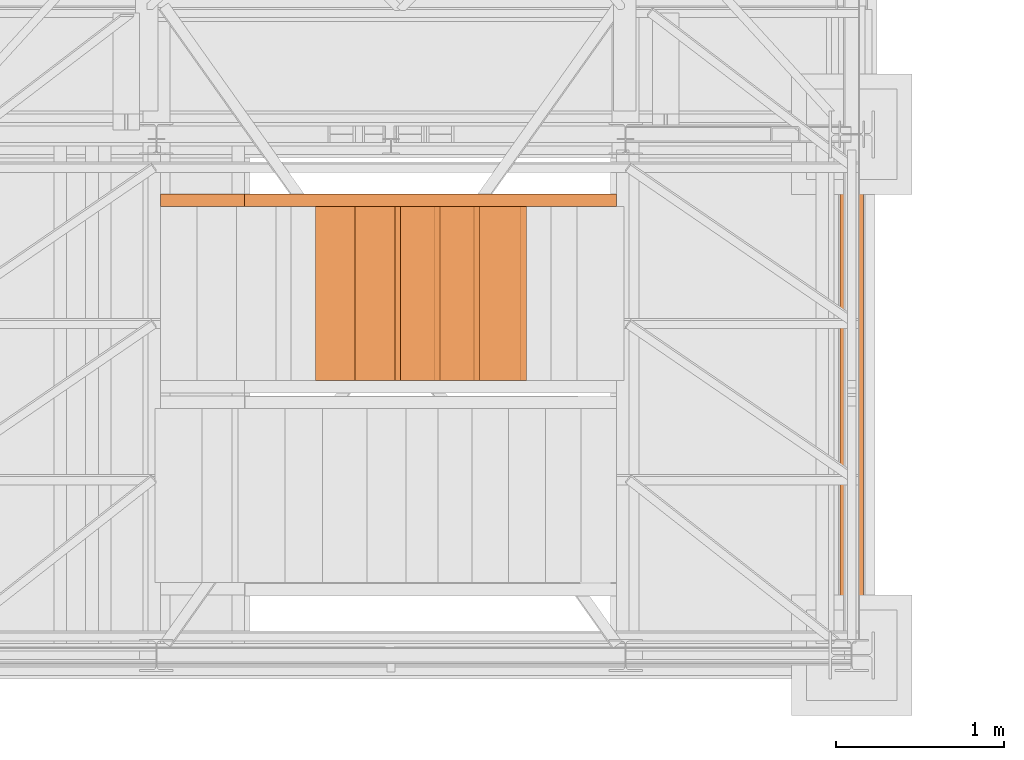
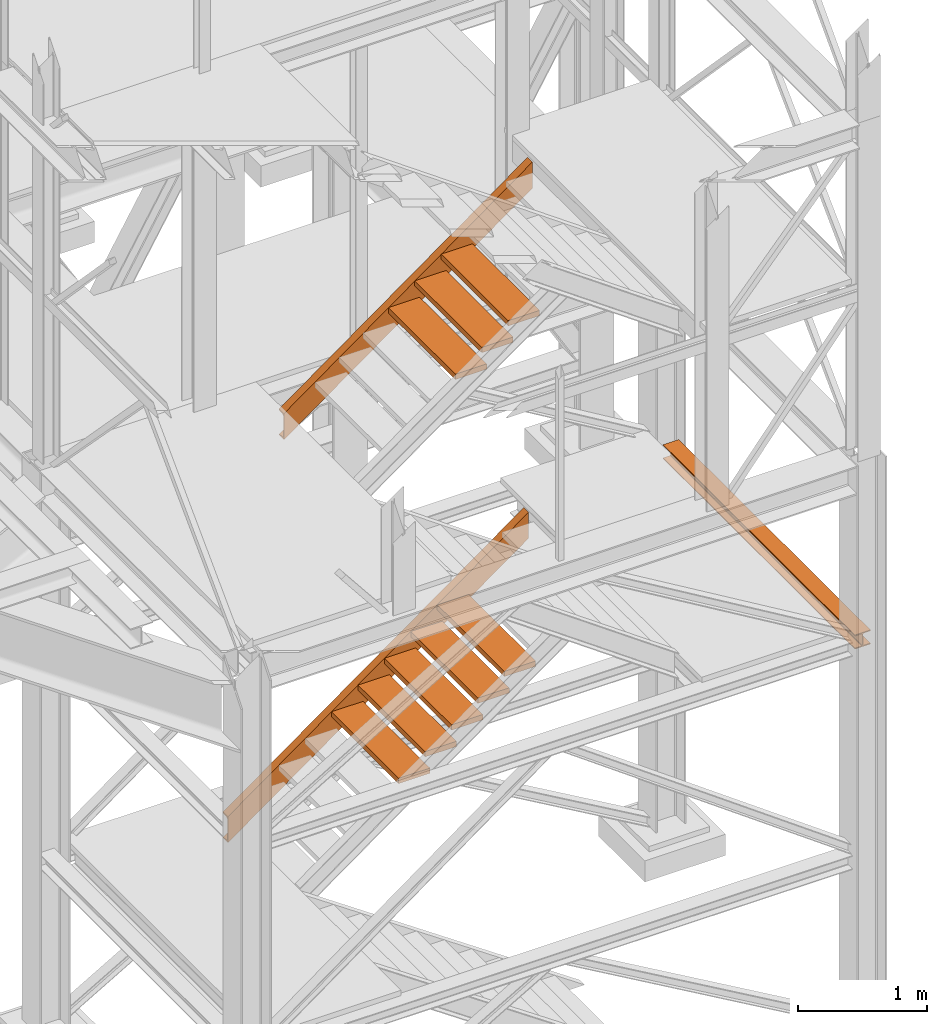
# One storey, part 52 of 208: 11 proxies.
"""IFC2X3 building model written with IfcOpenShell, lengths in millimetres."""

from ifc_helpers import new_model, entity, si_unit, converted_unit, frame, origin, origin_with_axes, place, context, subcontext, project, spatial, faceted_brep, element, save


model = new_model("IFC2X3")

# Units and contexts
model_context = context("Model", 3, precision=1e-05, world=origin())
plan_context = context("Plan", 3, precision=1e-05, world=origin())
body_context = subcontext(model_context, "Body", "Model", "MODEL_VIEW")
ifc_project = project(units=[si_unit("LENGTHUNIT", "METRE", prefix="MILLI"), converted_unit("PLANEANGLEUNIT", "DEGREE", entity("IfcPlaneAngleMeasure", 0.0174532925199433), si_unit("PLANEANGLEUNIT", "RADIAN"), dimensions=[0, 0, 0, 0, 0, 0, 0]), si_unit("AREAUNIT", "SQUARE_METRE"), si_unit("VOLUMEUNIT", "CUBIC_METRE")], contexts=[model_context, plan_context])

# Building, storey
building_placement = place(None, origin())
building = spatial("IfcBuilding", under=ifc_project, at=building_placement, CompositionType="COMPLEX")
storey_placement = place(building_placement, origin_with_axes())
storey = spatial("IfcBuildingStorey", under=building, at=storey_placement, Name="Geschoss", CompositionType="ELEMENT")

# Proxies
proxy_1_placement = place(storey_placement, frame((2573.108528797216, -22492.72083116692, 1416.268085031043), z_axis=(0.0, 0.0, 1.0), x_axis=(1.0, 0.0, 0.0)))
element("IfcBuildingElementProxy", 1, at=proxy_1_placement, inside=storey, context=body_context, shape_type="Brep", body=[
    faceted_brep([(0.01000000000112777, 0.00999999999839929, 0.01000000000021828), (0.01000000000112777, 0.00999999999839929, 246.5232555097177), (2685.302879462902, 0.00999999999839929, 2181.461873163844), (2685.302879462901, 0.00999999999839929, 1934.948617654126), (0.01000000000112777, 75.01000111758549, 0.01000000000021828), (0.01000000000112777, 0.00999999999839929, 0.01000000000021828), (2685.302879462901, 0.00999999999839929, 1934.948617654126), (2685.302879462901, 75.01000111758549, 1934.948617654126), (0.01000000000112777, 75.01000111758549, 3.659420299631847), (0.01000000000112777, 75.01000111758549, 0.01000000000021828), (2685.302879462901, 75.01000111758549, 1934.948617654126), (2685.302879462902, 75.01000111758549, 1938.598037953758), (0.01000000000203727, 73.89400100171406, 9.080250677066488), (0.01000000000112777, 75.01000111758549, 3.659420299631847), (2685.302879462902, 75.01000111758549, 1938.598037953758), (2685.302879462902, 73.89400100171406, 1944.018868331193), (0.01000000000112777, 69.488472694753, 11.03126840622554), (0.01000000000203727, 73.89400100171406, 9.080250677066488), (2685.302879462902, 73.89400100171406, 1944.018868331193), (2685.302879462902, 69.488472694753, 1945.969886060354), (0.01000000000112777, 19.09293180167515, 16.0005358716694), (0.01000000000112777, 69.488472694753, 11.03126840622554), (2685.302879462902, 69.488472694753, 1945.969886060354), (2685.302879462902, 19.09293180167515, 1950.939153525796), (0.01000000000112777, 13.35380079060633, 17.96675201902212), (0.01000000000112777, 19.09293180167515, 16.0005358716694), (2685.302879462902, 19.09293180167515, 1950.939153525796), (2685.302879462902, 13.35380079060633, 1952.905369673149), (0.01000000000203727, 9.500150026975462, 23.24250408189437), (0.01000000000112777, 13.35380079060633, 17.96675201902212), (2685.302879462902, 13.35380079060633, 1952.905369673149), (2685.302879462902, 9.500150026975462, 1958.181121736021), (0.01000000000021828, 8.510000461934396, 30.12990375652862), (0.01000000000203727, 9.500150026975462, 23.24250408189437), (2685.302879462902, 9.500150026975462, 1958.181121736021), (2685.302879462901, 8.510000461934396, 1965.068521410656), (0.01000000000112777, 8.510000461934396, 216.4033517531852), (0.01000000000021828, 8.510000461934396, 30.12990375652862), (2685.302879462901, 8.510000461934396, 1965.068521410656), (2685.302879462902, 8.510000461934396, 2151.341969407312), (0.01000000000112777, 9.500150026975462, 223.2907514278231), (0.01000000000112777, 8.510000461934396, 216.4033517531852), (2685.302879462902, 8.510000461934396, 2151.341969407312), (2685.302879462901, 9.500150026975462, 2158.229369081949), (0.01000000000112777, 13.35380079060633, 228.566503490694), (0.01000000000112777, 9.500150026975462, 223.2907514278231), (2685.302879462901, 9.500150026975462, 2158.229369081949), (2685.302879462901, 13.35380079060633, 2163.505121144821), (0.01000000000112777, 19.09293180167515, 230.5327196380472), (0.01000000000112777, 13.35380079060633, 228.566503490694), (2685.302879462901, 13.35380079060633, 2163.505121144821), (2685.302879462902, 19.09293180167515, 2165.471337292173), (0.01000000000112777, 69.488472694753, 235.5019871034892), (0.01000000000112777, 19.09293180167515, 230.5327196380472), (2685.302879462902, 19.09293180167515, 2165.471337292173), (2685.302879462902, 69.488472694753, 2170.440604757616), (0.01000000000112777, 73.89400100171406, 237.4530048326515), (0.01000000000112777, 69.488472694753, 235.5019871034892), (2685.302879462902, 69.488472694753, 2170.440604757616), (2685.302879462902, 73.89400100171406, 2172.391622486778), (0.01000000000112777, 75.01000111758549, 242.873835210085), (0.01000000000112777, 73.89400100171406, 237.4530048326515), (2685.302879462902, 73.89400100171406, 2172.391622486778), (2685.302879462902, 75.01000111758549, 2177.812452864211), (0.01000000000112777, 75.01000111758549, 246.5232555097175), (0.01000000000112777, 75.01000111758549, 242.873835210085), (2685.302879462902, 75.01000111758549, 2177.812452864211), (2685.302879462902, 75.01000111758549, 2181.461873163844), (0.01000000000112777, 0.00999999999839929, 246.5232555097177), (0.01000000000112777, 75.01000111758549, 246.5232555097175), (2685.302879462902, 75.01000111758549, 2181.461873163844), (2685.302879462902, 0.00999999999839929, 2181.461873163844), (2685.302879462901, 0.00999999999839929, 1934.948617654126), (2685.302879462902, 0.00999999999839929, 2181.461873163844), (2685.302879462902, 75.01000111758549, 2181.461873163844), (2685.302879462902, 75.01000111758549, 2177.812452864211), (2685.302879462902, 73.89400100171406, 2172.391622486778), (2685.302879462902, 69.488472694753, 2170.440604757616), (2685.302879462902, 19.09293180167515, 2165.471337292173), (2685.302879462901, 13.35380079060633, 2163.505121144821), (2685.302879462901, 9.500150026975462, 2158.229369081949), (2685.302879462902, 8.510000461934396, 2151.341969407312), (2685.302879462901, 8.510000461934396, 1965.068521410656), (2685.302879462902, 9.500150026975462, 1958.181121736021), (2685.302879462902, 13.35380079060633, 1952.905369673149), (2685.302879462902, 19.09293180167515, 1950.939153525796), (2685.302879462902, 69.488472694753, 1945.969886060354), (2685.302879462902, 73.89400100171406, 1944.018868331193), (2685.302879462902, 75.01000111758549, 1938.598037953758), (2685.302879462901, 75.01000111758549, 1934.948617654126), (0.01000000000112777, 0.00999999999839929, 246.5232555097177), (0.01000000000112777, 0.00999999999839929, 0.01000000000021828), (0.01000000000112777, 75.01000111758549, 0.01000000000021828), (0.01000000000112777, 75.01000111758549, 3.659420299631847), (0.01000000000203727, 73.89400100171406, 9.080250677066488), (0.01000000000112777, 69.488472694753, 11.03126840622554), (0.01000000000112777, 19.09293180167515, 16.0005358716694), (0.01000000000112777, 13.35380079060633, 17.96675201902212), (0.01000000000203727, 9.500150026975462, 23.24250408189437), (0.01000000000021828, 8.510000461934396, 30.12990375652862), (0.01000000000112777, 8.510000461934396, 216.4033517531852), (0.01000000000112777, 9.500150026975462, 223.2907514278231), (0.01000000000112777, 13.35380079060633, 228.566503490694), (0.01000000000112777, 19.09293180167515, 230.5327196380472), (0.01000000000112777, 69.488472694753, 235.5019871034892), (0.01000000000112777, 73.89400100171406, 237.4530048326515), (0.01000000000112777, 75.01000111758549, 242.873835210085), (0.01000000000112777, 75.01000111758549, 246.5232555097175)], [[[0, 1, 2, 3]], [[4, 5, 6, 7]], [[8, 9, 10, 11]], [[12, 13, 14, 15]], [[16, 17, 18, 19]], [[20, 21, 22, 23]], [[24, 25, 26, 27]], [[28, 29, 30, 31]], [[32, 33, 34, 35]], [[36, 37, 38, 39]], [[40, 41, 42, 43]], [[44, 45, 46, 47]], [[48, 49, 50, 51]], [[52, 53, 54, 55]], [[56, 57, 58, 59]], [[60, 61, 62, 63]], [[64, 65, 66, 67]], [[68, 69, 70, 71]], [[72, 73, 74, 75, 76, 77, 78, 79, 80, 81, 82, 83, 84, 85, 86, 87, 88, 89]], [[90, 91, 92, 93, 94, 95, 96, 97, 98, 99, 100, 101, 102, 103, 104, 105, 106, 107]]], orient=[[False], [False], [False], [False], [False], [False], [False], [False], [False], [False], [False], [False], [False], [False], [False], [False], [False], [False], [False], [False]]),
])
for number, where, z_axis, x_axis in (
    (2, (3499.055558253344, -23530.42800187884, 2279.990001055714), (0.0, 0.0, 1.0), (1.0, 0.0, 0.0)),
    (3, (3734.980246170392, -23530.42800187884, 2449.990001055715), (0.0, 0.0, 1.0), (1.0, 0.0, 0.0)),
):
    element("IfcBuildingElementProxy", number, at=place(storey_placement, frame(where, z_axis=z_axis, x_axis=x_axis)), inside=storey, context=body_context, shape_type="Brep", body=[
        faceted_brep([(0.01000000000021828, 0.00999999999839929, 0.01000000000021828), (280.2746556316183, 0.00999999999839929, 0.01000000000021828), (280.2746556316183, 1037.717170711916, 0.01000000000021828), (0.01000000000021828, 1037.717170711916, 0.01000000000021828), (280.2746556316183, 0.00999999999839929, 50.01000000000022), (0.01000000000021828, 0.00999999999839929, 50.01000000000022), (0.01000000000021828, 1037.717170711916, 50.01000000000022), (280.2746556316183, 1037.717170711916, 50.01000000000022), (280.2746556316183, 0.00999999999839929, 0.01000000000021828), (0.01000000000021828, 0.00999999999839929, 0.01000000000021828), (0.01000000000021828, 0.00999999999839929, 50.01000000000022), (280.2746556316183, 0.00999999999839929, 50.01000000000022), (280.2746556316183, 1037.717170711916, 0.01000000000021828), (280.2746556316183, 0.00999999999839929, 0.01000000000021828), (280.2746556316183, 0.00999999999839929, 50.01000000000022), (280.2746556316183, 1037.717170711916, 50.01000000000022), (0.01000000000021828, 1037.717170711916, 0.01000000000021828), (280.2746556316183, 1037.717170711916, 0.01000000000021828), (280.2746556316183, 1037.717170711916, 50.01000000000022), (0.01000000000021828, 1037.717170711916, 50.01000000000022), (0.01000000000021828, 0.00999999999839929, 0.01000000000021828), (0.01000000000021828, 1037.717170711916, 0.01000000000021828), (0.01000000000021828, 1037.717170711916, 50.01000000000022), (0.01000000000021828, 0.00999999999839929, 50.01000000000022)], [[[0, 1, 2, 3]], [[4, 5, 6, 7]], [[8, 9, 10, 11]], [[12, 13, 14, 15]], [[16, 17, 18, 19]], [[20, 21, 22, 23]]], orient=[[False], [False], [False], [False], [False], [False]]),
    ])
for number, where, z_axis, x_axis in (
    (4, (3970.904934087441, -23530.42800187884, 2619.990001055715), (0.0, 0.0, 1.0), (1.0, 0.0, 0.0)),
    (5, (4206.829622004489, -23530.42800187884, 2789.990001055716), (0.0, 0.0, 1.0), (1.0, 0.0, 0.0)),
    (6, (4442.754309921536, -23530.42800187884, 2959.990001055716), (0.0, 0.0, 1.0), (1.0, 0.0, 0.0)),
):
    element("IfcBuildingElementProxy", number, at=place(storey_placement, frame(where, z_axis=z_axis, x_axis=x_axis)), inside=storey, context=body_context, shape_type="Brep", body=[
        faceted_brep([(0.009999999999308784, 0.00999999999839929, 0.01000000000021828), (280.2746556316179, 0.00999999999839929, 0.01000000000021828), (280.2746556316179, 1037.717170711916, 0.01000000000021828), (0.009999999999308784, 1037.717170711916, 0.01000000000021828), (280.2746556316179, 0.00999999999839929, 50.01000000000022), (0.009999999999308784, 0.00999999999839929, 50.01000000000022), (0.009999999999308784, 1037.717170711916, 50.01000000000022), (280.2746556316179, 1037.717170711916, 50.01000000000022), (280.2746556316179, 0.00999999999839929, 0.01000000000021828), (0.009999999999308784, 0.00999999999839929, 0.01000000000021828), (0.009999999999308784, 0.00999999999839929, 50.01000000000022), (280.2746556316179, 0.00999999999839929, 50.01000000000022), (280.2746556316179, 1037.717170711916, 0.01000000000021828), (280.2746556316179, 0.00999999999839929, 0.01000000000021828), (280.2746556316179, 0.00999999999839929, 50.01000000000022), (280.2746556316179, 1037.717170711916, 50.01000000000022), (0.009999999999308784, 1037.717170711916, 0.01000000000021828), (280.2746556316179, 1037.717170711916, 0.01000000000021828), (280.2746556316179, 1037.717170711916, 50.01000000000022), (0.009999999999308784, 1037.717170711916, 50.01000000000022), (0.009999999999308784, 0.00999999999839929, 0.01000000000021828), (0.009999999999308784, 1037.717170711916, 0.01000000000021828), (0.009999999999308784, 1037.717170711916, 50.01000000000022), (0.009999999999308784, 0.00999999999839929, 50.01000000000022)], [[[0, 1, 2, 3]], [[4, 5, 6, 7]], [[8, 9, 10, 11]], [[12, 13, 14, 15]], [[16, 17, 18, 19]], [[20, 21, 22, 23]]], orient=[[False], [False], [False], [False], [False], [False]]),
    ])
proxy_2_placement = place(storey_placement, frame((3073.108528797206, -22492.72083116692, 5047.33263761315), z_axis=(0.0, 0.0, 1.0), x_axis=(1.0, 0.0, 0.0)))
element("IfcBuildingElementProxy", 7, at=proxy_2_placement, inside=storey, context=body_context, shape_type="Brep", body=[
    faceted_brep([(0.01000000000112777, 0.00999999999839929, 0.01000000000021828), (0.01000000000112777, 0.00999999999839929, 246.5232555097173), (2220.302879462911, 0.00999999999839929, 1846.397320581737), (2220.30287946291, 0.00999999999839929, 1599.884065072019), (0.01000000000112777, 75.01000111758549, 0.01000000000021828), (0.01000000000112777, 0.00999999999839929, 0.01000000000021828), (2220.30287946291, 0.00999999999839929, 1599.884065072019), (2220.30287946291, 75.01000111758549, 1599.884065072019), (0.01000000000112777, 75.01000111758549, 3.659420299631165), (0.01000000000112777, 75.01000111758549, 0.01000000000021828), (2220.30287946291, 75.01000111758549, 1599.884065072019), (2220.302879462911, 75.01000111758549, 1603.533485371651), (0.01000000000203727, 73.89400100171406, 9.080250677066033), (0.01000000000112777, 75.01000111758549, 3.659420299631165), (2220.302879462911, 75.01000111758549, 1603.533485371651), (2220.302879462911, 73.89400100171406, 1608.954315749086), (0.01000000000112777, 69.488472694753, 11.03126840622463), (0.01000000000203727, 73.89400100171406, 9.080250677066033), (2220.302879462911, 73.89400100171406, 1608.954315749086), (2220.302879462911, 69.488472694753, 1610.905333478248), (0.01000000000112777, 19.09293180167515, 16.00053587166894), (0.01000000000112777, 69.488472694753, 11.03126840622463), (2220.302879462911, 69.488472694753, 1610.905333478248), (2220.302879462911, 19.09293180167515, 1615.874600943689), (0.01000000000112777, 13.35380079060633, 17.96675201902144), (0.01000000000112777, 19.09293180167515, 16.00053587166894), (2220.302879462911, 19.09293180167515, 1615.874600943689), (2220.302879462911, 13.35380079060633, 1617.840817091042), (0.01000000000203727, 9.500150026975462, 23.24250408189437), (0.01000000000112777, 13.35380079060633, 17.96675201902144), (2220.302879462911, 13.35380079060633, 1617.840817091042), (2220.302879462911, 9.500150026975462, 1623.116569153914), (0.01000000000021828, 8.510000461934396, 30.12990375652771), (0.01000000000203727, 9.500150026975462, 23.24250408189437), (2220.302879462911, 9.500150026975462, 1623.116569153914), (2220.30287946291, 8.510000461934396, 1630.003968828549), (0.01000000000112777, 8.510000461934396, 216.4033517531843), (0.01000000000021828, 8.510000461934396, 30.12990375652771), (2220.30287946291, 8.510000461934396, 1630.003968828549), (2220.302879462911, 8.510000461934396, 1816.277416825205), (0.01000000000112777, 9.500150026975462, 223.2907514278231), (0.01000000000112777, 8.510000461934396, 216.4033517531843), (2220.302879462911, 8.510000461934396, 1816.277416825205), (2220.30287946291, 9.500150026975462, 1823.164816499842), (0.01000000000112777, 13.35380079060633, 228.5665034906933), (0.01000000000112777, 9.500150026975462, 223.2907514278231), (2220.30287946291, 9.500150026975462, 1823.164816499842), (2220.30287946291, 13.35380079060633, 1828.440568562714), (0.01000000000112777, 19.09293180167515, 230.5327196380467), (0.01000000000112777, 13.35380079060633, 228.5665034906933), (2220.30287946291, 13.35380079060633, 1828.440568562714), (2220.302879462911, 19.09293180167515, 1830.406784710067), (0.01000000000112777, 69.488472694753, 235.5019871034892), (0.01000000000112777, 19.09293180167515, 230.5327196380467), (2220.302879462911, 19.09293180167515, 1830.406784710067), (2220.302879462911, 69.488472694753, 1835.376052175508), (0.01000000000112777, 73.89400100171406, 237.4530048326506), (0.01000000000112777, 69.488472694753, 235.5019871034892), (2220.302879462911, 69.488472694753, 1835.376052175508), (2220.302879462911, 73.89400100171406, 1837.327069904672), (0.01000000000112777, 75.01000111758549, 242.8738352100845), (0.01000000000112777, 73.89400100171406, 237.4530048326506), (2220.302879462911, 73.89400100171406, 1837.327069904672), (2220.302879462911, 75.01000111758549, 1842.747900282104), (0.01000000000112777, 75.01000111758549, 246.5232555097173), (0.01000000000112777, 75.01000111758549, 242.8738352100845), (2220.302879462911, 75.01000111758549, 1842.747900282104), (2220.302879462911, 75.01000111758549, 1846.397320581737), (0.01000000000112777, 0.00999999999839929, 246.5232555097173), (0.01000000000112777, 75.01000111758549, 246.5232555097173), (2220.302879462911, 75.01000111758549, 1846.397320581737), (2220.302879462911, 0.00999999999839929, 1846.397320581737), (2220.30287946291, 0.00999999999839929, 1599.884065072019), (2220.302879462911, 0.00999999999839929, 1846.397320581737), (2220.302879462911, 75.01000111758549, 1846.397320581737), (2220.302879462911, 75.01000111758549, 1842.747900282104), (2220.302879462911, 73.89400100171406, 1837.327069904672), (2220.302879462911, 69.488472694753, 1835.376052175508), (2220.302879462911, 19.09293180167515, 1830.406784710067), (2220.30287946291, 13.35380079060633, 1828.440568562714), (2220.30287946291, 9.500150026975462, 1823.164816499842), (2220.302879462911, 8.510000461934396, 1816.277416825205), (2220.30287946291, 8.510000461934396, 1630.003968828549), (2220.302879462911, 9.500150026975462, 1623.116569153914), (2220.302879462911, 13.35380079060633, 1617.840817091042), (2220.302879462911, 19.09293180167515, 1615.874600943689), (2220.302879462911, 69.488472694753, 1610.905333478248), (2220.302879462911, 73.89400100171406, 1608.954315749086), (2220.302879462911, 75.01000111758549, 1603.533485371651), (2220.30287946291, 75.01000111758549, 1599.884065072019), (0.01000000000112777, 0.00999999999839929, 246.5232555097173), (0.01000000000112777, 0.00999999999839929, 0.01000000000021828), (0.01000000000112777, 75.01000111758549, 0.01000000000021828), (0.01000000000112777, 75.01000111758549, 3.659420299631165), (0.01000000000203727, 73.89400100171406, 9.080250677066033), (0.01000000000112777, 69.488472694753, 11.03126840622463), (0.01000000000112777, 19.09293180167515, 16.00053587166894), (0.01000000000112777, 13.35380079060633, 17.96675201902144), (0.01000000000203727, 9.500150026975462, 23.24250408189437), (0.01000000000021828, 8.510000461934396, 30.12990375652771), (0.01000000000112777, 8.510000461934396, 216.4033517531843), (0.01000000000112777, 9.500150026975462, 223.2907514278231), (0.01000000000112777, 13.35380079060633, 228.5665034906933), (0.01000000000112777, 19.09293180167515, 230.5327196380467), (0.01000000000112777, 69.488472694753, 235.5019871034892), (0.01000000000112777, 73.89400100171406, 237.4530048326506), (0.01000000000112777, 75.01000111758549, 242.8738352100845), (0.01000000000112777, 75.01000111758549, 246.5232555097173)], [[[0, 1, 2, 3]], [[4, 5, 6, 7]], [[8, 9, 10, 11]], [[12, 13, 14, 15]], [[16, 17, 18, 19]], [[20, 21, 22, 23]], [[24, 25, 26, 27]], [[28, 29, 30, 31]], [[32, 33, 34, 35]], [[36, 37, 38, 39]], [[40, 41, 42, 43]], [[44, 45, 46, 47]], [[48, 49, 50, 51]], [[52, 53, 54, 55]], [[56, 57, 58, 59]], [[60, 61, 62, 63]], [[64, 65, 66, 67]], [[68, 69, 70, 71]], [[72, 73, 74, 75, 76, 77, 78, 79, 80, 81, 82, 83, 84, 85, 86, 87, 88, 89]], [[90, 91, 92, 93, 94, 95, 96, 97, 98, 99, 100, 101, 102, 103, 104, 105, 106, 107]]], orient=[[False], [False], [False], [False], [False], [False], [False], [False], [False], [False], [False], [False], [False], [False], [False], [False], [False], [False], [False], [False]]),
])
for number, where, z_axis, x_axis in (
    (8, (4477.754309921535, -23530.42800187884, 6259.049951791538), (0.0, 0.0, 1.0), (1.0, 0.0, 0.0)),
    (9, (4241.829622004487, -23530.42800187884, 6089.049951791537), (0.0, 0.0, 1.0), (1.0, 0.0, 0.0)),
    (10, (4005.904934087439, -23530.42800187884, 5919.049951791536), (0.0, 0.0, 1.0), (1.0, 0.0, 0.0)),
):
    element("IfcBuildingElementProxy", number, at=place(storey_placement, frame(where, z_axis=z_axis, x_axis=x_axis)), inside=storey, context=body_context, shape_type="Brep", body=[
        faceted_brep([(0.009999999999308784, 0.00999999999839929, 0.01000000000021828), (280.2746556316179, 0.00999999999839929, 0.01000000000021828), (280.2746556316179, 1037.717170711916, 0.01000000000021828), (0.009999999999308784, 1037.717170711916, 0.01000000000021828), (280.2746556316179, 0.00999999999839929, 50.01000000000022), (0.009999999999308784, 0.00999999999839929, 50.01000000000022), (0.009999999999308784, 1037.717170711916, 50.01000000000022), (280.2746556316179, 1037.717170711916, 50.01000000000022), (280.2746556316179, 0.00999999999839929, 0.01000000000021828), (0.009999999999308784, 0.00999999999839929, 0.01000000000021828), (0.009999999999308784, 0.00999999999839929, 50.01000000000022), (280.2746556316179, 0.00999999999839929, 50.01000000000022), (280.2746556316179, 1037.717170711916, 0.01000000000021828), (280.2746556316179, 0.00999999999839929, 0.01000000000021828), (280.2746556316179, 0.00999999999839929, 50.01000000000022), (280.2746556316179, 1037.717170711916, 50.01000000000022), (0.009999999999308784, 1037.717170711916, 0.01000000000021828), (280.2746556316179, 1037.717170711916, 0.01000000000021828), (280.2746556316179, 1037.717170711916, 50.01000000000022), (0.009999999999308784, 1037.717170711916, 50.01000000000022), (0.009999999999308784, 0.00999999999839929, 0.01000000000021828), (0.009999999999308784, 1037.717170711916, 0.01000000000021828), (0.009999999999308784, 1037.717170711916, 50.01000000000022), (0.009999999999308784, 0.00999999999839929, 50.01000000000022)], [[[0, 1, 2, 3]], [[4, 5, 6, 7]], [[8, 9, 10, 11]], [[12, 13, 14, 15]], [[16, 17, 18, 19]], [[20, 21, 22, 23]]], orient=[[False], [False], [False], [False], [False], [False]]),
    ])
proxy_3_placement = place(storey_placement, frame((6628.254968230642, -25168.5743901279, 3447.489998909947), z_axis=(0.0, 0.0, 1.0), x_axis=(1.0, 0.0, 0.0)))
element("IfcBuildingElementProxy", 11, at=proxy_3_placement, inside=storey, context=body_context, shape_type="Brep", body=[
    faceted_brep([(0.01000000000021828, 2966.009999213962, 8.510002324581365), (0.01000000000021828, 0.00999999999839929, 8.510002324581365), (0.01000000000021828, 0.00999999999839929, 0.01000000000021828), (0.01000000000021828, 2966.009999213962, 0.01000000000021828), (0.01000000000021828, 2966.009999213962, 0.01000000000021828), (0.01000000000021828, 0.00999999999839929, 0.01000000000021828), (140.0100005960467, 0.00999999999839929, 0.01000000000021828), (140.0100005960467, 2966.009999213962, 0.01000000000021828), (140.0100005960467, 2966.009999213962, 0.01000000000021828), (140.0100005960467, 0.00999999999839929, 0.01000000000021828), (140.0100005960467, 0.00999999999839929, 8.510002324581365), (140.0100005960467, 2966.009999213962, 8.510002324581365), (140.0100005960467, 2966.009999213962, 8.510002324581365), (140.0100005960467, 0.00999999999839929, 8.510002324581365), (84.76000038743041, 0.00999999999839929, 8.510002324581365), (84.76000038743041, 2966.009999213962, 8.510002324581365), (84.76000038743041, 2966.009999213962, 8.510002324581365), (84.76000038743041, 0.00999999999839929, 8.510002324581365), (78.54945996612332, 0.00999999999839929, 9.753034839630345), (78.54945996612332, 2966.009999213962, 9.753034839630345), (78.54945996612332, 2966.009999213962, 9.753034839630345), (78.54945996612332, 0.00999999999839929, 9.753034839630345), (74.00303279817126, 0.00999999999839929, 14.29946480155013), (74.00303279817126, 2966.009999213962, 14.29946480155013), (74.00303279817126, 2966.009999213962, 14.29946480155013), (74.00303279817126, 0.00999999999839929, 14.29946480155013), (72.76000051595292, 0.00999999999839929, 20.51000429153464), (72.76000051595292, 2966.009999213962, 20.51000429153464), (72.76000051595292, 2966.009999213962, 20.51000429153464), (72.76000051595292, 0.00999999999839929, 20.51000429153464), (72.76000051595292, 0.00999999999839929, 112.5100007450583), (72.76000051595292, 2966.009999213962, 112.5100007450583), (72.76000051595292, 2966.009999213962, 112.5100007450583), (72.76000051595292, 0.00999999999839929, 112.5100007450583), (74.00303279817126, 0.00999999999839929, 118.7205402350428), (74.00303279817126, 2966.009999213962, 118.7205402350428), (74.00303279817126, 2966.009999213962, 118.7205402350428), (74.00303279817126, 0.00999999999839929, 118.7205402350428), (78.54945996612332, 0.00999999999839929, 123.2669664716723), (78.54945996612332, 2966.009999213962, 123.2669664716723), (78.54945996612332, 2966.009999213962, 123.2669664716723), (78.54945996612332, 0.00999999999839929, 123.2669664716723), (84.76000038743041, 0.00999999999839929, 124.5099989867213), (84.76000038743041, 2966.009999213962, 124.5099989867213), (84.76000038743041, 2966.009999213962, 124.5099989867213), (84.76000038743041, 0.00999999999839929, 124.5099989867213), (140.0100005960467, 0.00999999999839929, 124.5099989867213), (140.0100005960467, 2966.009999213962, 124.5099989867213), (140.0100005960467, 2966.009999213962, 124.5099989867213), (140.0100005960467, 0.00999999999839929, 124.5099989867213), (140.0100005960467, 0.00999999999839929, 133.0100013113024), (140.0100005960467, 2966.009999213962, 133.0100013113024), (140.0100005960467, 2966.009999213962, 133.0100013113024), (140.0100005960467, 0.00999999999839929, 133.0100013113024), (0.01000000000021828, 0.00999999999839929, 133.0100013113024), (0.01000000000021828, 2966.009999213962, 133.0100013113024), (0.01000000000021828, 2966.009999213962, 133.0100013113024), (0.01000000000021828, 0.00999999999839929, 133.0100013113024), (0.01000000000021828, 0.00999999999839929, 124.5099989867213), (0.01000000000021828, 2966.009999213962, 124.5099989867213), (0.01000000000021828, 2966.009999213962, 124.5099989867213), (0.01000000000021828, 0.00999999999839929, 124.5099989867213), (55.26000020861648, 0.00999999999839929, 124.5099989867213), (55.26000020861648, 2966.009999213962, 124.5099989867213), (55.26000020861648, 2966.009999213962, 124.5099989867213), (55.26000020861648, 0.00999999999839929, 124.5099989867213), (61.47054062992356, 0.00999999999839929, 123.2669664716723), (61.47054062992356, 2966.009999213962, 123.2669664716723), (61.47054062992356, 2966.009999213962, 123.2669664716723), (61.47054062992356, 0.00999999999839929, 123.2669664716723), (66.01696779787562, 0.00999999999839929, 118.7205402350428), (66.01696779787562, 2966.009999213962, 118.7205402350428), (66.01696779787562, 2966.009999213962, 118.7205402350428), (66.01696779787562, 0.00999999999839929, 118.7205402350428), (67.26000008009396, 0.00999999999839929, 112.5100007450583), (67.26000008009396, 2966.009999213962, 112.5100007450583), (67.26000008009396, 2966.009999213962, 112.5100007450583), (67.26000008009396, 0.00999999999839929, 112.5100007450583), (67.26000008009396, 0.00999999999839929, 20.51000429153464), (67.26000008009396, 2966.009999213962, 20.51000429153464), (67.26000008009396, 2966.009999213962, 20.51000429153464), (67.26000008009396, 0.00999999999839929, 20.51000429153464), (66.01696779787562, 0.00999999999839929, 14.29946480155013), (66.01696779787562, 2966.009999213962, 14.29946480155013), (66.01696779787562, 2966.009999213962, 14.29946480155013), (66.01696779787562, 0.00999999999839929, 14.29946480155013), (61.47054062992356, 0.00999999999839929, 9.753034839630345), (61.47054062992356, 2966.009999213962, 9.753034839630345), (61.47054062992356, 2966.009999213962, 9.753034839630345), (61.47054062992356, 0.00999999999839929, 9.753034839630345), (55.26000020861648, 0.00999999999839929, 8.510002324581365), (55.26000020861648, 2966.009999213962, 8.510002324581365), (55.26000020861648, 2966.009999213962, 8.510002324581365), (55.26000020861648, 0.00999999999839929, 8.510002324581365), (0.01000000000021828, 0.00999999999839929, 8.510002324581365), (0.01000000000021828, 2966.009999213962, 8.510002324581365), (0.01000000000021828, 0.00999999999839929, 8.510002324581365), (55.26000020861648, 0.00999999999839929, 8.510002324581365), (61.47054062992356, 0.00999999999839929, 9.753034839630345), (66.01696779787562, 0.00999999999839929, 14.29946480155013), (67.26000008009396, 0.00999999999839929, 20.51000429153464), (67.26000008009396, 0.00999999999839929, 112.5100007450583), (66.01696779787562, 0.00999999999839929, 118.7205402350428), (61.47054062992356, 0.00999999999839929, 123.2669664716723), (55.26000020861648, 0.00999999999839929, 124.5099989867213), (0.01000000000021828, 0.00999999999839929, 124.5099989867213), (0.01000000000021828, 0.00999999999839929, 133.0100013113024), (140.0100005960467, 0.00999999999839929, 133.0100013113024), (140.0100005960467, 0.00999999999839929, 124.5099989867213), (84.76000038743041, 0.00999999999839929, 124.5099989867213), (78.54945996612332, 0.00999999999839929, 123.2669664716723), (74.00303279817126, 0.00999999999839929, 118.7205402350428), (72.76000051595292, 0.00999999999839929, 112.5100007450583), (72.76000051595292, 0.00999999999839929, 20.51000429153464), (74.00303279817126, 0.00999999999839929, 14.29946480155013), (78.54945996612332, 0.00999999999839929, 9.753034839630345), (84.76000038743041, 0.00999999999839929, 8.510002324581365), (140.0100005960467, 0.00999999999839929, 8.510002324581365), (140.0100005960467, 0.00999999999839929, 0.01000000000021828), (0.01000000000021828, 0.00999999999839929, 0.01000000000021828), (0.01000000000021828, 2966.009999213962, 0.01000000000021828), (140.0100005960467, 2966.009999213962, 0.01000000000021828), (140.0100005960467, 2966.009999213962, 8.510002324581365), (84.76000038743041, 2966.009999213962, 8.510002324581365), (78.54945996612332, 2966.009999213962, 9.753034839630345), (74.00303279817126, 2966.009999213962, 14.29946480155013), (72.76000051595292, 2966.009999213962, 20.51000429153464), (72.76000051595292, 2966.009999213962, 112.5100007450583), (74.00303279817126, 2966.009999213962, 118.7205402350428), (78.54945996612332, 2966.009999213962, 123.2669664716723), (84.76000038743041, 2966.009999213962, 124.5099989867213), (140.0100005960467, 2966.009999213962, 124.5099989867213), (140.0100005960467, 2966.009999213962, 133.0100013113024), (0.01000000000021828, 2966.009999213962, 133.0100013113024), (0.01000000000021828, 2966.009999213962, 124.5099989867213), (55.26000020861648, 2966.009999213962, 124.5099989867213), (61.47054062992356, 2966.009999213962, 123.2669664716723), (66.01696779787562, 2966.009999213962, 118.7205402350428), (67.26000008009396, 2966.009999213962, 112.5100007450583), (67.26000008009396, 2966.009999213962, 20.51000429153464), (66.01696779787562, 2966.009999213962, 14.29946480155013), (61.47054062992356, 2966.009999213962, 9.753034839630345), (55.26000020861648, 2966.009999213962, 8.510002324581365), (0.01000000000021828, 2966.009999213962, 8.510002324581365)], [[[0, 1, 2, 3]], [[4, 5, 6, 7]], [[8, 9, 10, 11]], [[12, 13, 14, 15]], [[16, 17, 18, 19]], [[20, 21, 22, 23]], [[24, 25, 26, 27]], [[28, 29, 30, 31]], [[32, 33, 34, 35]], [[36, 37, 38, 39]], [[40, 41, 42, 43]], [[44, 45, 46, 47]], [[48, 49, 50, 51]], [[52, 53, 54, 55]], [[56, 57, 58, 59]], [[60, 61, 62, 63]], [[64, 65, 66, 67]], [[68, 69, 70, 71]], [[72, 73, 74, 75]], [[76, 77, 78, 79]], [[80, 81, 82, 83]], [[84, 85, 86, 87]], [[88, 89, 90, 91]], [[92, 93, 94, 95]], [[96, 97, 98, 99, 100, 101, 102, 103, 104, 105, 106, 107, 108, 109, 110, 111, 112, 113, 114, 115, 116, 117, 118, 119]], [[120, 121, 122, 123, 124, 125, 126, 127, 128, 129, 130, 131, 132, 133, 134, 135, 136, 137, 138, 139, 140, 141, 142, 143]]], orient=[[False], [False], [False], [False], [False], [False], [False], [False], [False], [False], [False], [False], [False], [False], [False], [False], [False], [False], [False], [False], [False], [False], [False], [False], [False], [False]]),
])

save(model, "model.ifc")
